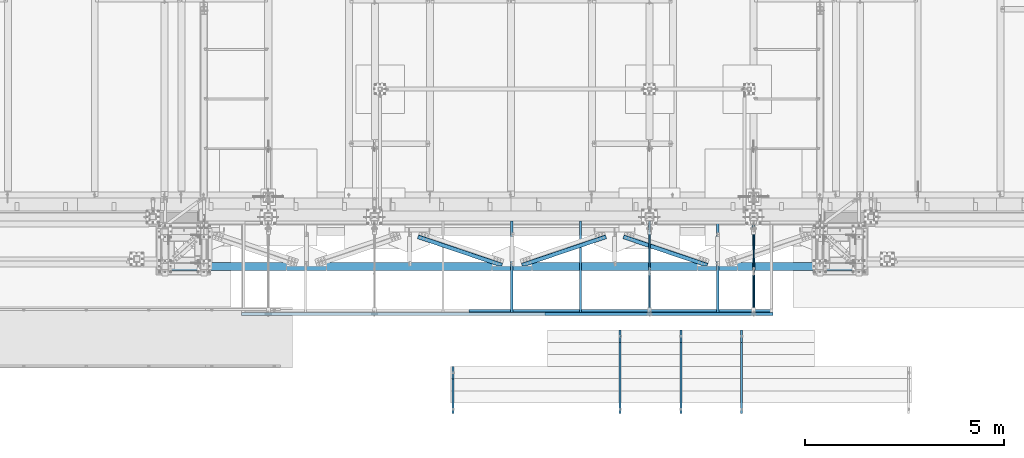
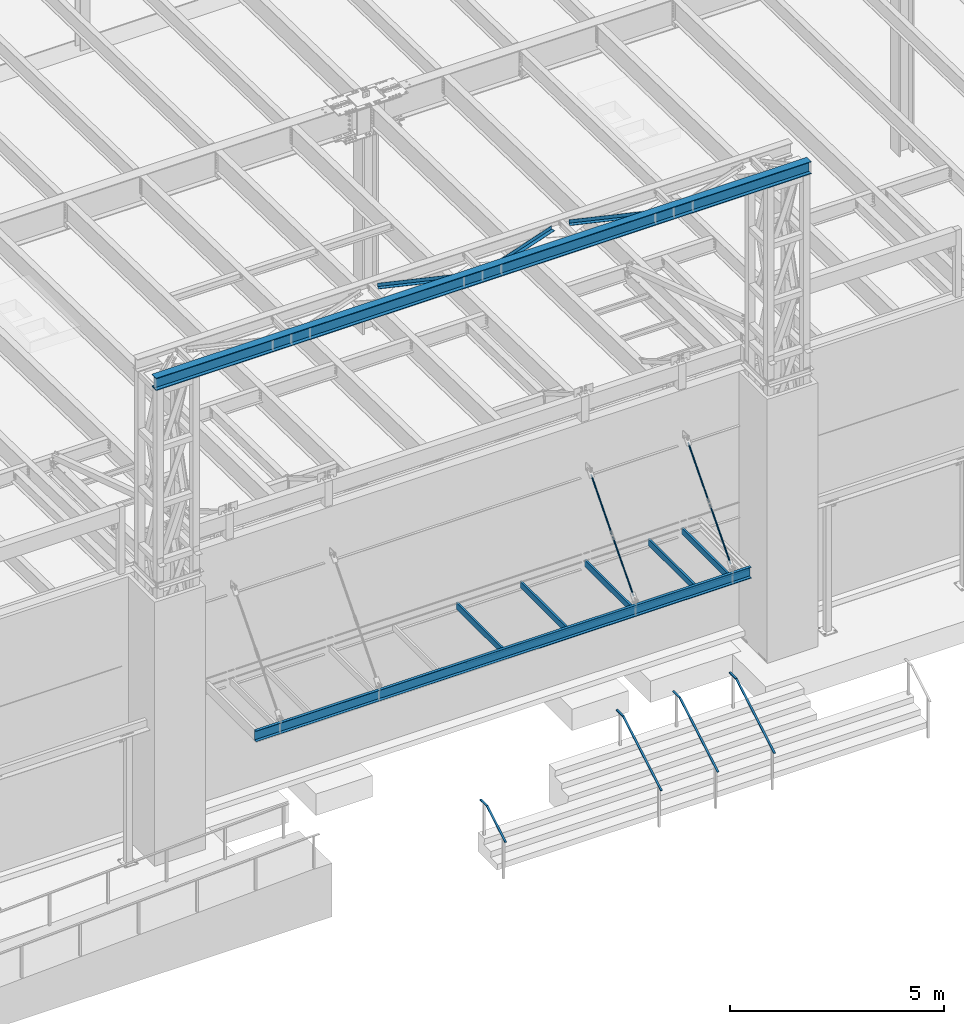
# One storey, part 1056 of 1763: 16 beams, 4 members, 16 elements without a shape of their own.
"""IFC2X3 building model written with IfcOpenShell, lengths in millimetres."""

from ifc_helpers import new_model, si_unit, frame, origin_with_axes, place, context, subcontext, project, spatial, faceted_brep, material, type_object, element, aggregate, save


model = new_model("IFC2X3")

# Units and contexts
model_context = context("Model", 3, precision=1e-05, world=origin_with_axes())
body_context = subcontext(model_context, "Body", "Model", "MODEL_VIEW")
ifc_project = project(units=[si_unit("LENGTHUNIT", "METRE", prefix="MILLI"), si_unit("AREAUNIT", "SQUARE_METRE"), si_unit("VOLUMEUNIT", "CUBIC_METRE"), si_unit("MASSUNIT", "GRAM", prefix="KILO"), si_unit("TIMEUNIT", "SECOND"), si_unit("PLANEANGLEUNIT", "RADIAN"), si_unit("SOLIDANGLEUNIT", "STERADIAN"), si_unit("THERMODYNAMICTEMPERATUREUNIT", "DEGREE_CELSIUS"), si_unit("LUMINOUSINTENSITYUNIT", "LUMEN")], contexts=[model_context])

# Site, building, storey
site_placement = place(None, origin_with_axes())
site = spatial("IfcSite", under=ifc_project, at=site_placement, CompositionType="ELEMENT")
building_placement = place(site_placement, origin_with_axes())
building = spatial("IfcBuilding", under=site, at=building_placement, Name="Undefined", CompositionType="ELEMENT")
storey_placement = place(building_placement, origin_with_axes())
storey = spatial("IfcBuildingStorey", under=building, at=storey_placement, Name="Undefined", CompositionType="ELEMENT", Elevation=0.0)

# Assembly, beam
assembly_1_placement = place(storey_placement, origin_with_axes())
assembly_1 = element("IfcElementAssembly", 1, at=assembly_1_placement, inside=storey, Name="BEAM", AssemblyPlace="NOTDEFINED", PredefinedType="RIGID_FRAME")
ifc_material_1 = material(Name="STEEL/A36")
beam_type_1 = type_object("IfcBeamType", Name="C12X20.7", PredefinedType="NOTDEFINED")
beam_1_placement = place(assembly_1_placement, frame((-62260.9785703209, -16643.3525869816, 8585.2), z_axis=(0.0, 0.0, 1.0), x_axis=(1.0, 0.0, 0.0)))
beam_1 = element("IfcBeam", 2, at=beam_1_placement, type_object=beam_type_1, material=ifc_material_1, Name="BEAM", ObjectType="C12X20.7", context=body_context, shape_type="Brep", body=[
    faceted_brep([(0.0, 38.1000000000004, -152.4), (0.0, 38.1000000000004, 152.4), (13347.3031240281, 38.0999999999985, 152.4), (13347.3031240281, 38.0999999999985, -152.4), (0.0, -38.1000000000004, 152.4), (13347.3031240281, -38.0999999999985, 152.4), (0.0, -38.1000000000004, 146.04746), (13347.3031240281, -38.0999999999985, 146.04746), (0.0, 30.1625000000004, 134.6749275), (13347.3031240281, 30.1624999999985, 134.6749275), (0.0, 30.1625000000004, -134.6749275), (13347.3031240281, 30.1624999999985, -134.6749275), (0.0, -38.1000000000004, -146.04746), (13347.3031240281, -38.0999999999985, -146.04746), (0.0, -38.1000000000004, -152.4), (13347.3031240281, -38.0999999999985, -152.4)], [[[0, 1, 2, 3]], [[1, 4, 5, 2]], [[4, 6, 7, 5]], [[6, 8, 9, 7]], [[8, 10, 11, 9]], [[10, 12, 13, 11]], [[12, 14, 15, 13]], [[14, 0, 3, 15]], [[5, 7, 9, 11, 13, 15, 3, 2]], [[14, 12, 10, 8, 6, 4, 1, 0]]]),
])

assembly_2_placement = place(storey_placement, origin_with_axes())
assembly_2 = element("IfcElementAssembly", 3, at=assembly_2_placement, inside=storey, Name="ANGLE", AssemblyPlace="NOTDEFINED", PredefinedType="RIGID_FRAME")
beam_type_2 = type_object("IfcBeamType", Name="L4X4X1/4", PredefinedType="NOTDEFINED")
beam_2_placement = place(assembly_2_placement, frame((-50331.0000497608, -15500.844871459, 18672.175), z_axis=(-0.320655198083929, -0.94719599024793, 0.0), x_axis=(-0.947195990247929, 0.320655198083932, 0.0)))
beam_2 = element("IfcBeam", 4, at=beam_2_placement, type_object=beam_type_2, material=ifc_material_1, Name="ANGLE", ObjectType="L4X4X1/4", context=body_context, shape_type="Brep", body=[
    faceted_brep([(248.939032899376, 44.4500000000007, 15.0208201336718), (248.939032899376, 50.7999999999993, 15.0208201336718), (248.93475632761, 50.7999999999993, -50.7999999996973), (248.93475632761, -50.7999999999993, -50.7999999996973), (248.935169854769, -50.7999999999993, -44.4499999997024), (248.935169854769, 44.4500000000007, -44.4499999997024), (354.581904417377, 44.4500000000007, 50.7769661094571), (354.58190441737, 50.7999999999993, 50.8000000003813), (2474.10695207783, 44.4500000000007, 50.7975799277119), (2474.10695220195, 50.7999999999993, 50.8000000027932), (2474.10174137646, 50.7999999999993, -50.7999999971726), (2474.10174137646, -50.7999999999993, -50.7999999971726), (2474.10206705305, -50.7999999999993, -44.449999997174), (2474.10206705305, 44.4500000000007, -44.449999997174)], [[[0, 1, 2, 3, 4, 5]], [[6, 7, 1, 0]], [[7, 6, 8, 9]], [[2, 1, 7, 9, 10]], [[3, 2, 10, 11]], [[4, 3, 11, 12]], [[5, 4, 12, 13]], [[6, 0, 5, 13, 8]], [[12, 11, 10, 9, 8, 13]]]),
])
aggregate(assembly_2, [beam_2])

assembly_3_placement = place(storey_placement, origin_with_axes())
assembly_3 = element("IfcElementAssembly", 5, at=assembly_3_placement, inside=storey, Name="ANGLE", AssemblyPlace="NOTDEFINED", PredefinedType="RIGID_FRAME")
beam_3_placement = place(assembly_3_placement, frame((-55489.3167822984, -15500.844871274, 18672.175), z_axis=(-0.320655198083929, -0.94719599024793, 0.0), x_axis=(-0.947195990247929, 0.320655198083932, 0.0)))
beam_3 = element("IfcBeam", 6, at=beam_3_placement, type_object=beam_type_2, material=ifc_material_1, Name="ANGLE", ObjectType="L4X4X1/4", context=body_context, shape_type="Brep", body=[
    faceted_brep([(248.939032899376, 44.4500000000007, 15.0208201336718), (248.939032899376, 50.7999999999993, 15.0208201336718), (248.93475632761, 50.7999999999993, -50.7999999996973), (248.93475632761, -50.7999999999993, -50.7999999996973), (248.935169854769, -50.7999999999993, -44.4499999997024), (248.935169854769, 44.4500000000007, -44.4499999997024), (354.581904417377, 44.4500000000007, 50.7769661094571), (354.58190441737, 50.7999999999993, 50.8000000003813), (2474.10695207783, 44.4500000000007, 50.7975799277119), (2474.10695220195, 50.7999999999993, 50.8000000027932), (2474.10174137646, 50.7999999999993, -50.7999999971726), (2474.10174137646, -50.7999999999993, -50.7999999971726), (2474.10206705305, -50.7999999999993, -44.449999997174), (2474.10206705305, 44.4500000000007, -44.449999997174)], [[[0, 1, 2, 3, 4, 5]], [[6, 7, 1, 0]], [[7, 6, 8, 9]], [[2, 1, 7, 9, 10]], [[3, 2, 10, 11]], [[4, 3, 11, 12]], [[5, 4, 12, 13]], [[6, 0, 5, 13, 8]], [[12, 11, 10, 9, 8, 13]]]),
])
aggregate(assembly_3, [beam_3])

assembly_4_placement = place(storey_placement, origin_with_axes())
assembly_4 = element("IfcElementAssembly", 7, at=assembly_4_placement, inside=storey, Name="ANGLE", AssemblyPlace="NOTDEFINED", PredefinedType="RIGID_FRAME")
beam_4_placement = place(assembly_4_placement, frame((-52877.5798425236, -14627.7198341673, 18672.175), z_axis=(0.320655215158338, -0.947195984467713, 0.0), x_axis=(-0.947195984467714, -0.320655215158336, 0.0)))
beam_4 = element("IfcBeam", 8, at=beam_4_placement, type_object=beam_type_2, material=ifc_material_1, Name="ANGLE", ObjectType="L4X4X1/4", context=body_context, shape_type="Brep", body=[
    faceted_brep([(2474.08815029644, 44.4500000000007, -44.4499999984348), (2474.08815029644, -50.7999999999993, -44.4499999984348), (2474.08778122983, -50.7999999999993, -50.7999999984352), (2474.08778122983, 50.7999999999993, -50.7999999984352), (2474.09159971638, 50.7999999999993, 15.0236743646817), (2474.09159971638, 44.4500000000007, 15.0236743646817), (2368.45312543344, 50.7999999999993, 50.8000000014833), (2368.45312543344, 44.4500000000007, 50.8000000014833), (248.928076724376, 44.4500000000007, 50.8000000001518), (248.921250277446, 44.4500000000007, -44.4499999998336), (248.921250277446, -50.7999999999993, -44.4499999998336), (248.920795180988, -50.7999999999993, -50.7999999998303), (248.920795180988, 50.7999999999993, -50.7999999998303), (248.928076724376, 50.7999999999993, 50.8000000001518)], [[[0, 1, 2, 3, 4, 5]], [[5, 4, 6, 7]], [[0, 5, 7, 8, 9]], [[1, 0, 9, 10]], [[2, 1, 10, 11]], [[3, 2, 11, 12]], [[6, 4, 3, 12, 13]], [[7, 6, 13, 8]], [[12, 11, 10, 9, 8, 13]]]),
])
aggregate(assembly_4, [beam_4])

# Beam
beam_type_3 = type_object("IfcBeamType", Name="L3X3X1/4", PredefinedType="NOTDEFINED")
beam_5_placement = place(assembly_1_placement, frame((-56554.3129440085, -16567.1521202467, 8648.7), z_axis=(0.0, 1.0, 0.0), x_axis=(1.0, 0.0, 0.0)))
beam_5 = element("IfcBeam", 9, at=beam_5_placement, type_object=beam_type_3, material=ifc_material_1, Name="ANGLE", ObjectType="L3X3X1/4", context=body_context, shape_type="Brep", body=[
    faceted_brep([(0.0, 38.0999999999985, -38.1000000000004), (0.0, 38.0999999999985, 38.1000000000004), (7620.00000001252, 38.1000000000004, 38.099999987593), (7620.00000001241, 38.1000000000004, -38.1000000124041), (0.0, 31.75, 38.1000000000058), (7620.00000001252, 31.75, 38.099999987593), (0.0, 31.75, -31.75), (7620.00000001241, 31.75, -31.7500000124055), (0.0, -38.1000000000004, -31.75), (7620.00000001241, -38.1000000000004, -31.7500000124055), (0.0, -38.0999999999985, -38.1000000000004), (7620.00000001241, -38.1000000000004, -38.1000000124041)], [[[0, 1, 2, 3]], [[1, 4, 5, 2]], [[4, 6, 7, 5]], [[6, 8, 9, 7]], [[8, 10, 11, 9]], [[10, 0, 3, 11]], [[5, 7, 9, 11, 3, 2]], [[10, 8, 6, 4, 1, 0]]]),
])

# Assembly, beam
assembly_5_placement = place(storey_placement, origin_with_axes())
assembly_5 = element("IfcElementAssembly", 10, at=assembly_5_placement, inside=storey, Name="HANDRAIL", AssemblyPlace="NOTDEFINED", PredefinedType="RIGID_FRAME")
beam_type_4 = type_object("IfcBeamType", PredefinedType="NOTDEFINED")
beam_6_placement = place(assembly_5_placement, frame((-52755.2372736984, -19143.8249145572, 5206.50837891029), z_axis=(-1.0, 0.0, 0.0), x_axis=(0.0, 0.863778900717086, 0.503871025834967)))
beam_6 = element("IfcBeam", 11, at=beam_6_placement, type_object=beam_type_4, material=ifc_material_1, Name="HANDRAIL", context=body_context, shape_type="Brep", body=[
    faceted_brep([(2.91038304567337e-11, -9.52499999999418, -25.4000000000015), (2.91038304567337e-11, -9.52499999999418, 25.4000000000015), (-5.82076609134674e-11, 9.52499999999418, 25.4000000000015), (-5.82076609134674e-11, 9.52499999999418, -25.4000000000015), (2065.19938791017, 9.52504462009711, 25.4000000000015), (2065.19938791017, 9.52504462009711, -25.4000000000015), (2070.3495392473, -9.52495526862185, -25.4000000000015), (2070.3495392473, -9.52495526862185, 25.4000000000015), (2326.25483773232, 161.807390474376, 25.4000000000015), (2326.25483773232, 161.807390474376, -25.4000000000015), (2335.85358077444, 145.352402415698, 25.4000000000015), (2335.85358077444, 145.352402415698, -25.4000000000015)], [[[0, 1, 2, 3]], [[3, 2, 4, 5]], [[1, 0, 6, 7]], [[5, 4, 8, 9]], [[4, 2, 1, 7, 10, 8]], [[7, 6, 11, 10]], [[6, 0, 3, 5, 9, 11]], [[10, 11, 9, 8]]]),
])
aggregate(assembly_5, [beam_6])

assembly_6_placement = place(storey_placement, origin_with_axes())
assembly_6 = element("IfcElementAssembly", 12, at=assembly_6_placement, inside=storey, Name="HANDRAIL", AssemblyPlace="NOTDEFINED", PredefinedType="RIGID_FRAME")
beam_7_placement = place(assembly_6_placement, frame((-49707.2372736984, -19143.8249145572, 5206.50837891029), z_axis=(-1.0, 0.0, 0.0), x_axis=(0.0, 0.863778900717086, 0.503871025834967)))
beam_7 = element("IfcBeam", 13, at=beam_7_placement, type_object=beam_type_4, material=ifc_material_1, Name="HANDRAIL", context=body_context, shape_type="Brep", body=[
    faceted_brep([(2.91038304567337e-11, -9.52499999999418, -25.4000000000015), (2.91038304567337e-11, -9.52499999999418, 25.4000000000015), (-5.82076609134674e-11, 9.52499999999418, 25.4000000000015), (-5.82076609134674e-11, 9.52499999999418, -25.4000000000015), (2065.19938791017, 9.52504462009711, 25.4000000000015), (2065.19938791017, 9.52504462009711, -25.4000000000015), (2070.3495392473, -9.52495526862185, -25.4000000000015), (2070.3495392473, -9.52495526862185, 25.4000000000015), (2326.25483773232, 161.807390474376, 25.4000000000015), (2326.25483773232, 161.807390474376, -25.4000000000015), (2335.85358077444, 145.352402415698, 25.4000000000015), (2335.85358077444, 145.352402415698, -25.4000000000015)], [[[0, 1, 2, 3]], [[3, 2, 4, 5]], [[1, 0, 6, 7]], [[5, 4, 8, 9]], [[4, 2, 1, 7, 10, 8]], [[7, 6, 11, 10]], [[6, 0, 3, 5, 9, 11]], [[10, 11, 9, 8]]]),
])
aggregate(assembly_6, [beam_7])

assembly_7_placement = place(storey_placement, origin_with_axes())
assembly_7 = element("IfcElementAssembly", 14, at=assembly_7_placement, inside=storey, Name="HANDRAIL", AssemblyPlace="NOTDEFINED", PredefinedType="RIGID_FRAME")
beam_8_placement = place(assembly_7_placement, frame((-51231.2372736984, -19143.8249145572, 5206.50837891029), z_axis=(-1.0, 0.0, 0.0), x_axis=(0.0, 0.863778900717086, 0.503871025834967)))
beam_8 = element("IfcBeam", 15, at=beam_8_placement, type_object=beam_type_4, material=ifc_material_1, Name="HANDRAIL", context=body_context, shape_type="Brep", body=[
    faceted_brep([(2.91038304567337e-11, -9.52499999999418, -25.4000000000015), (2.91038304567337e-11, -9.52499999999418, 25.4000000000015), (-5.82076609134674e-11, 9.52499999999418, 25.4000000000015), (-5.82076609134674e-11, 9.52499999999418, -25.4000000000015), (2065.19938791017, 9.52504462009711, 25.4000000000015), (2065.19938791017, 9.52504462009711, -25.4000000000015), (2070.3495392473, -9.52495526862185, -25.4000000000015), (2070.3495392473, -9.52495526862185, 25.4000000000015), (2326.25483773232, 161.807390474376, 25.4000000000015), (2326.25483773232, 161.807390474376, -25.4000000000015), (2335.85358077444, 145.352402415698, 25.4000000000015), (2335.85358077444, 145.352402415698, -25.4000000000015)], [[[0, 1, 2, 3]], [[3, 2, 4, 5]], [[1, 0, 6, 7]], [[5, 4, 8, 9]], [[4, 2, 1, 7, 10, 8]], [[7, 6, 11, 10]], [[6, 0, 3, 5, 9, 11]], [[10, 11, 9, 8]]]),
])
aggregate(assembly_7, [beam_8])

assembly_8_placement = place(storey_placement, origin_with_axes())
assembly_8 = element("IfcElementAssembly", 16, at=assembly_8_placement, inside=storey, Name="HANDRAIL", AssemblyPlace="NOTDEFINED", PredefinedType="RIGID_FRAME")
beam_9_placement = place(assembly_8_placement, frame((-56952.5872736984, -19143.8248832361, 5206.50837891029), z_axis=(-1.0, 0.0, 0.0), x_axis=(0.0, 0.863778900717086, 0.503871025834967)))
beam_9 = element("IfcBeam", 17, at=beam_9_placement, type_object=beam_type_4, material=ifc_material_1, Name="HANDRAIL", context=body_context, shape_type="Brep", body=[
    faceted_brep([(2.91038304567337e-11, -9.52499999999418, -25.4000000000015), (2.91038304567337e-11, -9.52499999999418, 25.4000000000015), (-5.82076609134674e-11, 9.52499999999418, 25.4000000000015), (-5.82076609134674e-11, 9.52499999999418, -25.4000000000015), (1006.59513807963, 9.52500455970767, 25.4000000000015), (1006.59513807963, 9.52500455970767, -25.4000000000015), (1011.74528904162, -9.52499541697944, -25.4000000000015), (1011.74528904162, -9.52499541697944, 25.4000000000015), (1267.65059126487, 161.807344696828, 25.4000000000015), (1267.65059126487, 161.807344696828, -25.4000000000015), (1277.2493339458, 145.352356427451, 25.4000000000015), (1277.2493339458, 145.352356427451, -25.4000000000015)], [[[0, 1, 2, 3]], [[3, 2, 4, 5]], [[1, 0, 6, 7]], [[5, 4, 8, 9]], [[4, 2, 1, 7, 10, 8]], [[7, 6, 11, 10]], [[6, 0, 3, 5, 9, 11]], [[10, 11, 9, 8]]]),
])
aggregate(assembly_8, [beam_9])

# Beam
beam_type_5 = type_object("IfcBeamType", PredefinedType="NOTDEFINED")
beam_10_placement = place(assembly_1_placement, frame((-54641.1770086929, -16605.2525498317, 8426.45000000022), z_axis=(0.0, 1.0, 0.0), x_axis=(1.0, 0.0, 0.0)))
beam_10 = element("IfcBeam", 18, at=beam_10_placement, type_object=beam_type_5, material=ifc_material_1, Name="PLATE", context=body_context, shape_type="Brep", body=[
    faceted_brep([(4.36557456851006e-11, 6.35000000000036, -76.2000000000044), (-4.72937244921923e-11, 6.35000000000036, 76.1999999999898), (5727.50156201937, 6.35000000000036, 76.2000000055705), (5727.50156201896, 6.35000000000036, -76.199999994431), (-4.72937244921923e-11, -6.35000000000036, 76.1999999999898), (5727.50156201937, -6.35000000000036, 76.2000000055705), (4.36557456851006e-11, -6.35000000000036, -76.2000000000044), (5727.50156201896, -6.35000000000036, -76.199999994431)], [[[0, 1, 2, 3]], [[1, 4, 5, 2]], [[4, 6, 7, 5]], [[6, 0, 3, 7]], [[5, 7, 3, 2]], [[6, 4, 1, 0]]]),
])

aggregate(assembly_1, [beam_5, beam_10, beam_1])

# Assembly, beam
assembly_9_placement = place(storey_placement, origin_with_axes())
assembly_9 = element("IfcElementAssembly", 19, at=assembly_9_placement, inside=storey, Name="BEAM", AssemblyPlace="NOTDEFINED", PredefinedType="RIGID_FRAME")
beam_type_6 = type_object("IfcBeamType", Name="C7X9.8", PredefinedType="NOTDEFINED")
beam_11_placement = place(assembly_9_placement, frame((-50306.508257937, -16605.2525869701, 8521.7), z_axis=(0.0, 0.0, 1.0), x_axis=(0.0, 1.0, 0.0)))
beam_11 = element("IfcBeam", 20, at=beam_11_placement, type_object=beam_type_6, material=ifc_material_1, Name="BEAM", ObjectType="C7X9.8", context=body_context, shape_type="Brep", body=[
    faceted_brep([(0.0, 26.9875000000029, -88.8999999999996), (0.0, 26.9875000000029, 88.8999999999996), (2295.52499752098, 26.9875000000029, 88.8999999999996), (2295.52499752098, 26.9875000000029, -88.8999999999996), (0.0, -26.9875000000029, 88.8999999999996), (2295.52499752098, -26.9875000000029, 88.8999999999996), (0.0, -26.9875000000029, 83.8711175000008), (2295.52499752098, -26.9875000000029, 83.8711175000008), (0.0, 22.2249999999985, 75.6723149999998), (2295.52499752098, 22.2249999999985, 75.6723149999998), (0.0, 22.2249999999985, -75.6723149999998), (2295.52499752098, 22.2249999999985, -75.6723149999998), (0.0, -26.9875000000029, -83.8711175000008), (2295.52499752098, -26.9875000000029, -83.8711175000008), (0.0, -26.9875000000029, -88.8999999999996), (2295.52499752098, -26.9875000000029, -88.8999999999996)], [[[0, 1, 2, 3]], [[1, 4, 5, 2]], [[4, 6, 7, 5]], [[6, 8, 9, 7]], [[8, 10, 11, 9]], [[10, 12, 13, 11]], [[12, 14, 15, 13]], [[14, 0, 3, 15]], [[5, 7, 9, 11, 13, 15, 3, 2]], [[14, 12, 10, 8, 6, 4, 1, 0]]]),
])
aggregate(assembly_9, [beam_11])

assembly_10_placement = place(storey_placement, origin_with_axes())
assembly_10 = element("IfcElementAssembly", 21, at=assembly_10_placement, inside=storey, Name="BEAM", AssemblyPlace="NOTDEFINED", PredefinedType="RIGID_FRAME")
beam_12_placement = place(assembly_10_placement, frame((-49402.4270083119, -16605.2526189353, 8521.7), z_axis=(0.0, 0.0, 1.0), x_axis=(0.0, 1.0, 0.0)))
beam_12 = element("IfcBeam", 22, at=beam_12_placement, type_object=beam_type_6, material=ifc_material_1, Name="BEAM", ObjectType="C7X9.8", context=body_context, shape_type="Brep", body=[
    faceted_brep([(0.0, 26.9875000000029, -88.8999999999996), (0.0, 26.9875000000029, 88.8999999999996), (2295.52499752098, 26.9875000000029, 88.8999999999996), (2295.52499752098, 26.9875000000029, -88.8999999999996), (0.0, -26.9875000000029, 88.8999999999996), (2295.52499752098, -26.9875000000029, 88.8999999999996), (0.0, -26.9875000000029, 83.8711175000008), (2295.52499752098, -26.9875000000029, 83.8711175000008), (0.0, 22.2249999999985, 75.6723149999998), (2295.52499752098, 22.2249999999985, 75.6723149999998), (0.0, 22.2249999999985, -75.6723149999998), (2295.52499752098, 22.2249999999985, -75.6723149999998), (0.0, -26.9875000000029, -83.8711175000008), (2295.52499752098, -26.9875000000029, -83.8711175000008), (0.0, -26.9875000000029, -88.8999999999996), (2295.52499752098, -26.9875000000029, -88.8999999999996)], [[[0, 1, 2, 3]], [[1, 4, 5, 2]], [[4, 6, 7, 5]], [[6, 8, 9, 7]], [[8, 10, 11, 9]], [[10, 12, 13, 11]], [[12, 14, 15, 13]], [[14, 0, 3, 15]], [[5, 7, 9, 11, 13, 15, 3, 2]], [[14, 12, 10, 8, 6, 4, 1, 0]]]),
])
aggregate(assembly_10, [beam_12])

assembly_11_placement = place(storey_placement, origin_with_axes())
assembly_11 = element("IfcElementAssembly", 23, at=assembly_11_placement, inside=storey, Name="BEAM", AssemblyPlace="NOTDEFINED", PredefinedType="RIGID_FRAME")
beam_13_placement = place(assembly_11_placement, frame((-52018.627008321, -16605.2521202467, 8521.7), z_axis=(0.0, 0.0, 1.0), x_axis=(0.0, 1.0, 0.0)))
beam_13 = element("IfcBeam", 24, at=beam_13_placement, type_object=beam_type_6, material=ifc_material_1, Name="BEAM", ObjectType="C7X9.8", context=body_context, shape_type="Brep", body=[
    faceted_brep([(0.0, 26.9875000000029, -88.8999999999996), (0.0, 26.9875000000029, 88.8999999999996), (2295.52453083604, 26.9875000000029, 88.8999999999996), (2295.52453083604, 26.9875000000029, -88.8999999999996), (0.0, -26.9875000000029, 88.8999999999996), (2295.52453083604, -26.9875000000029, 88.8999999999996), (0.0, -26.9875000000029, 83.8711175000008), (2295.52453083604, -26.9875000000029, 83.8711175000008), (0.0, 22.2249999999985, 75.6723149999998), (2295.52453083604, 22.2249999999985, 75.6723149999998), (0.0, 22.2249999999985, -75.6723149999998), (2295.52453083604, 22.2249999999985, -75.6723149999998), (0.0, -26.9875000000029, -83.8711175000008), (2295.52453083604, -26.9875000000029, -83.8711175000008), (0.0, -26.9875000000029, -88.8999999999996), (2295.52453083604, -26.9875000000029, -88.8999999999996)], [[[0, 1, 2, 3]], [[1, 4, 5, 2]], [[4, 6, 7, 5]], [[6, 8, 9, 7]], [[8, 10, 11, 9]], [[10, 12, 13, 11]], [[12, 14, 15, 13]], [[14, 0, 3, 15]], [[5, 7, 9, 11, 13, 15, 3, 2]], [[14, 12, 10, 8, 6, 4, 1, 0]]]),
])
aggregate(assembly_11, [beam_13])

assembly_12_placement = place(storey_placement, origin_with_axes())
assembly_12 = element("IfcElementAssembly", 25, at=assembly_12_placement, inside=storey, Name="BEAM", AssemblyPlace="NOTDEFINED", PredefinedType="RIGID_FRAME")
beam_14_placement = place(assembly_12_placement, frame((-53756.1457586958, -16605.2525869388, 8521.7), z_axis=(0.0, 0.0, 1.0), x_axis=(0.0, 1.0, 0.0)))
beam_14 = element("IfcBeam", 26, at=beam_14_placement, type_object=beam_type_6, material=ifc_material_1, Name="BEAM", ObjectType="C7X9.8", context=body_context, shape_type="Brep", body=[
    faceted_brep([(0.0, 26.9875000000029, -88.8999999999996), (0.0, 26.9875000000029, 88.8999999999996), (2295.52499752098, 26.9875000000029, 88.8999999999996), (2295.52499752098, 26.9875000000029, -88.8999999999996), (0.0, -26.9875000000029, 88.8999999999996), (2295.52499752098, -26.9875000000029, 88.8999999999996), (0.0, -26.9875000000029, 83.8711175000008), (2295.52499752098, -26.9875000000029, 83.8711175000008), (0.0, 22.2249999999985, 75.6723149999998), (2295.52499752098, 22.2249999999985, 75.6723149999998), (0.0, 22.2249999999985, -75.6723149999998), (2295.52499752098, 22.2249999999985, -75.6723149999998), (0.0, -26.9875000000029, -83.8711175000008), (2295.52499752098, -26.9875000000029, -83.8711175000008), (0.0, -26.9875000000029, -88.8999999999996), (2295.52499752098, -26.9875000000029, -88.8999999999996)], [[[0, 1, 2, 3]], [[1, 4, 5, 2]], [[4, 6, 7, 5]], [[6, 8, 9, 7]], [[8, 10, 11, 9]], [[10, 12, 13, 11]], [[12, 14, 15, 13]], [[14, 0, 3, 15]], [[5, 7, 9, 11, 13, 15, 3, 2]], [[14, 12, 10, 8, 6, 4, 1, 0]]]),
])
aggregate(assembly_12, [beam_14])

assembly_13_placement = place(storey_placement, origin_with_axes())
assembly_13 = element("IfcElementAssembly", 27, at=assembly_13_placement, inside=storey, Name="BEAM", AssemblyPlace="NOTDEFINED", PredefinedType="RIGID_FRAME")
beam_15_placement = place(assembly_13_placement, frame((-55480.9645090798, -16605.2525869325, 8521.7), z_axis=(0.0, 0.0, 1.0), x_axis=(0.0, 1.0, 0.0)))
beam_15 = element("IfcBeam", 28, at=beam_15_placement, type_object=beam_type_6, material=ifc_material_1, Name="BEAM", ObjectType="C7X9.8", context=body_context, shape_type="Brep", body=[
    faceted_brep([(0.0, 26.9875000000029, -88.8999999999996), (0.0, 26.9875000000029, 88.8999999999996), (2295.52499752098, 26.9875000000029, 88.8999999999996), (2295.52499752098, 26.9875000000029, -88.8999999999996), (0.0, -26.9875000000029, 88.8999999999996), (2295.52499752098, -26.9875000000029, 88.8999999999996), (0.0, -26.9875000000029, 83.8711175000008), (2295.52499752098, -26.9875000000029, 83.8711175000008), (0.0, 22.2249999999985, 75.6723149999998), (2295.52499752098, 22.2249999999985, 75.6723149999998), (0.0, 22.2249999999985, -75.6723149999998), (2295.52499752098, 22.2249999999985, -75.6723149999998), (0.0, -26.9875000000029, -83.8711175000008), (2295.52499752098, -26.9875000000029, -83.8711175000008), (0.0, -26.9875000000029, -88.8999999999996), (2295.52499752098, -26.9875000000029, -88.8999999999996)], [[[0, 1, 2, 3]], [[1, 4, 5, 2]], [[4, 6, 7, 5]], [[6, 8, 9, 7]], [[8, 10, 11, 9]], [[10, 12, 13, 11]], [[12, 14, 15, 13]], [[14, 0, 3, 15]], [[5, 7, 9, 11, 13, 15, 3, 2]], [[14, 12, 10, 8, 6, 4, 1, 0]]]),
])
aggregate(assembly_13, [beam_15])

# Assembly, members
assembly_14_placement = place(storey_placement, origin_with_axes())
assembly_14 = element("IfcElementAssembly", 29, at=assembly_14_placement, inside=storey, Name="HANGER ROD", AssemblyPlace="NOTDEFINED", PredefinedType="RIGID_FRAME")
ifc_material_2 = material()
member_type = type_object("IfcMemberType", PredefinedType="NOTDEFINED")
member_1_placement = place(assembly_14_placement, frame((-49402.4270098514, -15572.8018592845, 10059.9757394587), z_axis=(0.0, -0.751852283110682, 0.659331589097061), x_axis=(0.0, 0.659331589097062, 0.75185228311068)))
member_1 = element("IfcMember", 30, at=member_1_placement, type_object=member_type, material=ifc_material_2, Name="BEAM", context=body_context, shape_type="Brep", body=[
    faceted_brep([(1503.04093508851, -7.9375, -13.7481532849306), (1503.04093478259, 0.0, -15.8749999998545), (1503.04093508851, 7.9375, -13.7481532849306), (1503.04093592429, 13.7481532850798, -7.93749999985448), (1503.04093706599, 15.875, 1.41881173476577e-10), (1503.0409382077, 13.7481532850798, 7.93750000013824), (1503.04093904348, 7.9375, 13.748153285218), (1503.0409393494, 0.0, 15.8750000001382), (1503.04093904348, -7.9375, 13.748153285218), (1503.0409382077, -13.7481532850798, 7.93750000013824), (1503.04093706599, -15.875, 1.41881173476577e-10), (1503.04093592429, -13.7481532850798, -7.93749999985448), (25.399999995976, -7.93750000389264, 13.7481538153661), (25.3999999959769, -3.89263732358813e-09, 15.8750005302863), (25.3999999959751, -13.7481532889724, 7.93750053028998), (25.3999999959788, -15.8750000038926, 5.30293618794531e-07), (25.3999999959779, -13.7481532889724, -7.93749946969911), (25.3999999959797, -7.93750000389264, -13.7481527547752), (25.3999999959797, -3.89263732358813e-09, -15.8749994696918), (25.3999999959797, 7.93749999610736, -13.7481527547752), (25.3999999959779, 13.7481532811871, -7.93749946969911), (25.3999996185303, 15.8749999962647, 0.0), (25.3999999959751, 13.7481532811871, 7.93750053028998), (25.399999995976, 7.93749999610736, 13.7481538153661), (177.799999998953, 7.9375, 13.7481532850943)], [[[0, 1, 2, 3, 4, 5, 6, 7, 8, 9, 10, 11]], [[12, 8, 7, 13]], [[14, 9, 8, 12]], [[15, 10, 9, 14]], [[16, 11, 10, 15]], [[17, 0, 11, 16]], [[18, 1, 0, 17]], [[19, 2, 1, 18]], [[20, 3, 2, 19]], [[21, 4, 3, 20]], [[22, 5, 4, 21]], [[23, 24, 6, 5, 22]], [[23, 13, 7, 6, 24]], [[22, 21, 20, 19, 18, 17, 16, 15, 14, 12, 13, 23]]]),
])
member_2_placement = place(assembly_14_placement, frame((-49402.4270098475, -16643.3525869314, 8839.20000000015), z_axis=(0.0, -0.751852283110682, 0.659331589097061), x_axis=(0.0, 0.659331589097062, 0.75185228311068)))
member_2 = element("IfcMember", 31, at=member_2_placement, type_object=member_type, material=ifc_material_2, Name="HANGER ROD", context=body_context, shape_type="Brep", body=[
    faceted_brep([(120.649999999407, -13.7481532850798, 7.93750000002183), (120.649999999399, -7.9375, 13.7481532851089), (120.649999999397, 0.0, 15.8750000000327), (120.649999999399, 7.9375, 13.7481532851089), (120.649999999407, 13.7481532850798, 7.93750000002183), (120.649999999417, 15.875, 1.45519152283669e-11), (120.649999999425, 13.7481532850798, -7.93749999999272), (120.649999999432, 7.9375, -13.7481532850798), (120.649999999433, 0.0, -15.875), (120.649999999432, -7.9375, -13.7481532850798), (120.649999999425, -13.7481532850798, -7.93749999999272), (120.649999999417, -15.875, 1.45519152283669e-11), (1598.29093934174, 7.9375, 13.7481532763995), (1598.29093934174, 0.0, 15.8749999913271), (1598.29093934175, 13.7481532850798, 7.93749999131251), (1598.29093934176, 15.875, -8.70568328537047e-09), (1598.29093934177, 13.7481532850798, -7.93750000872024), (1598.29093934178, 7.9375, -13.7481532938109), (1598.29093934178, 0.0, -15.8750000087384), (1598.29093934178, -7.9375, -13.7481532938109), (1598.29093934177, -13.7481532850798, -7.93750000872024), (1598.29093934176, -15.875, -8.70568328537047e-09), (1598.29093934175, -13.7481532850798, 7.93749999131251), (1598.29093934174, -7.9375, 13.7481532763995)], [[[0, 1, 2, 3, 4, 5, 6, 7, 8, 9, 10, 11]], [[12, 3, 2, 13]], [[14, 4, 3, 12]], [[15, 5, 4, 14]], [[16, 6, 5, 15]], [[17, 7, 6, 16]], [[18, 8, 7, 17]], [[19, 9, 8, 18]], [[20, 10, 9, 19]], [[21, 11, 10, 20]], [[22, 0, 11, 21]], [[23, 1, 0, 22]], [[23, 13, 2, 1]], [[16, 15, 14, 12, 13, 23, 22, 21, 20, 19, 18, 17]]]),
])
aggregate(assembly_14, [member_1, member_2])

assembly_15_placement = place(storey_placement, origin_with_axes())
assembly_15 = element("IfcElementAssembly", 32, at=assembly_15_placement, inside=storey, Name="HANGER ROD", AssemblyPlace="NOTDEFINED", PredefinedType="RIGID_FRAME")
member_3_placement = place(assembly_15_placement, frame((-52018.627008321, -15572.8018593345, 10059.9757394587), z_axis=(0.0, -0.751852283110682, 0.659331589097061), x_axis=(0.0, 0.659331589097062, 0.75185228311068)))
member_3 = element("IfcMember", 33, at=member_3_placement, type_object=member_type, material=ifc_material_2, Name="BEAM", context=body_context, shape_type="Brep", body=[
    faceted_brep([(1503.04093508851, -7.9375, -13.7481532849306), (1503.04093478259, 0.0, -15.8749999998545), (1503.04093508851, 7.9375, -13.7481532849306), (1503.04093592429, 13.7481532850798, -7.93749999985448), (1503.04093706599, 15.875, 1.41881173476577e-10), (1503.0409382077, 13.7481532850798, 7.93750000013824), (1503.04093904348, 7.9375, 13.748153285218), (1503.0409393494, 0.0, 15.8750000001382), (1503.04093904348, -7.9375, 13.748153285218), (1503.0409382077, -13.7481532850798, 7.93750000013824), (1503.04093706599, -15.875, 1.41881173476577e-10), (1503.04093592429, -13.7481532850798, -7.93749999985448), (25.399999995976, -7.93750000389264, 13.7481538153661), (25.3999999959769, -3.89263732358813e-09, 15.8750005302863), (25.3999999959751, -13.7481532889724, 7.93750053028998), (25.3999999959788, -15.8750000038926, 5.30293618794531e-07), (25.3999999959779, -13.7481532889724, -7.93749946969911), (25.3999999959797, -7.93750000389264, -13.7481527547752), (25.3999999959797, -3.89263732358813e-09, -15.8749994696918), (25.3999999959797, 7.93749999610736, -13.7481527547752), (25.3999999959779, 13.7481532811871, -7.93749946969911), (25.3999996185303, 15.8749999962647, 0.0), (25.3999999959751, 13.7481532811871, 7.93750053028998), (25.399999995976, 7.93749999610736, 13.7481538153661), (177.799999998953, 7.9375, 13.7481532850943)], [[[0, 1, 2, 3, 4, 5, 6, 7, 8, 9, 10, 11]], [[12, 8, 7, 13]], [[14, 9, 8, 12]], [[15, 10, 9, 14]], [[16, 11, 10, 15]], [[17, 0, 11, 16]], [[18, 1, 0, 17]], [[19, 2, 1, 18]], [[20, 3, 2, 19]], [[21, 4, 3, 20]], [[22, 5, 4, 21]], [[23, 24, 6, 5, 22]], [[23, 13, 7, 6, 24]], [[22, 21, 20, 19, 18, 17, 16, 15, 14, 12, 13, 23]]]),
])
member_4_placement = place(assembly_15_placement, frame((-52018.627008321, -16643.3525869814, 8839.20000000015), z_axis=(0.0, -0.751852283110682, 0.659331589097061), x_axis=(0.0, 0.659331589097062, 0.75185228311068)))
member_4 = element("IfcMember", 34, at=member_4_placement, type_object=member_type, material=ifc_material_2, Name="HANGER ROD", context=body_context, shape_type="Brep", body=[
    faceted_brep([(120.649999999407, -13.7481532850798, 7.93750000002183), (120.649999999399, -7.9375, 13.7481532851089), (120.649999999397, 0.0, 15.8750000000327), (120.649999999399, 7.9375, 13.7481532851089), (120.649999999407, 13.7481532850798, 7.93750000002183), (120.649999999417, 15.875, 1.45519152283669e-11), (120.649999999425, 13.7481532850798, -7.93749999999272), (120.649999999432, 7.9375, -13.7481532850798), (120.649999999433, 0.0, -15.875), (120.649999999432, -7.9375, -13.7481532850798), (120.649999999425, -13.7481532850798, -7.93749999999272), (120.649999999417, -15.875, 1.45519152283669e-11), (1598.29093934174, 7.9375, 13.7481532763995), (1598.29093934174, 0.0, 15.8749999913271), (1598.29093934175, 13.7481532850798, 7.93749999131251), (1598.29093934176, 15.875, -8.70568328537047e-09), (1598.29093934177, 13.7481532850798, -7.93750000872024), (1598.29093934178, 7.9375, -13.7481532938109), (1598.29093934178, 0.0, -15.8750000087384), (1598.29093934178, -7.9375, -13.7481532938109), (1598.29093934177, -13.7481532850798, -7.93750000872024), (1598.29093934176, -15.875, -8.70568328537047e-09), (1598.29093934175, -13.7481532850798, 7.93749999131251), (1598.29093934174, -7.9375, 13.7481532763995)], [[[0, 1, 2, 3, 4, 5, 6, 7, 8, 9, 10, 11]], [[12, 3, 2, 13]], [[14, 4, 3, 12]], [[15, 5, 4, 14]], [[16, 6, 5, 15]], [[17, 7, 6, 16]], [[18, 8, 7, 17]], [[19, 9, 8, 18]], [[20, 10, 9, 19]], [[21, 11, 10, 20]], [[22, 0, 11, 21]], [[23, 1, 0, 22]], [[23, 13, 2, 1]], [[16, 15, 14, 12, 13, 23, 22, 21, 20, 19, 18, 17]]]),
])
aggregate(assembly_15, [member_3, member_4])

# Assembly, beam
assembly_16_placement = place(storey_placement, origin_with_axes())
assembly_16 = element("IfcElementAssembly", 35, at=assembly_16_placement, inside=storey, Name="BEAM", AssemblyPlace="NOTDEFINED", PredefinedType="RIGID_FRAME")
ifc_material_3 = material(Name="STEEL/A992")
beam_type_7 = type_object("IfcBeamType", Name="W14X53", PredefinedType="NOTDEFINED")
beam_16_placement = place(assembly_16_placement, frame((-64299.5277903703, -15452.7272094127, 18645.1875), z_axis=(0.0, 0.0, 1.0), x_axis=(1.0, 0.0, 0.0)))
beam_16 = element("IfcBeam", 36, at=beam_16_placement, type_object=beam_type_7, material=ifc_material_3, Name="BEAM", ObjectType="W14X53", context=body_context, shape_type="Brep", body=[
    faceted_brep([(2.69210431724787e-10, 101.599999999999, -176.212500000001), (2.69210431724787e-10, 101.599999999999, -158.75), (17653.0005866402, 101.599999985063, -158.75), (17653.0005866402, 101.599999985063, -176.212500000001), (1.45519152283669e-11, 4.76249999999891, -158.75), (17653.00058664, 4.76249998506319, -158.75), (1.45519152283669e-11, 4.76249999999891, 158.75), (17653.00058664, 4.76249998506319, 158.75), (2.69210431724787e-10, 101.599999999999, 158.75), (17653.0005866402, 101.599999985063, 158.75), (2.69210431724787e-10, 101.599999999999, 176.212500000001), (17653.0005866402, 101.599999985063, 176.212500000001), (-2.69210431724787e-10, -101.600000000002, 176.212500000001), (17653.0005866397, -101.600000014938, 176.212500000001), (-2.69210431724787e-10, -101.600000000002, 158.75), (17653.0005866397, -101.600000014938, 158.75), (-1.45519152283669e-11, -4.76250000000255, 158.75), (17653.0005866399, -4.76250001493827, 158.75), (-1.45519152283669e-11, -4.76250000000255, -158.75), (17653.0005866399, -4.76250001493827, -158.75), (-2.69210431724787e-10, -101.600000000002, -158.75), (17653.0005866397, -101.600000014938, -158.75), (-2.69210431724787e-10, -101.600000000002, -176.212500000001), (17653.0005866397, -101.600000014938, -176.212500000001)], [[[0, 1, 2, 3]], [[1, 4, 5, 2]], [[4, 6, 7, 5]], [[6, 8, 9, 7]], [[8, 10, 11, 9]], [[10, 12, 13, 11]], [[12, 14, 15, 13]], [[14, 16, 17, 15]], [[16, 18, 19, 17]], [[18, 20, 21, 19]], [[20, 22, 23, 21]], [[22, 0, 3, 23]], [[5, 7, 9, 11, 13, 15, 17, 19, 21, 23, 3, 2]], [[22, 20, 18, 16, 14, 12, 10, 8, 6, 4, 1, 0]]]),
])
aggregate(assembly_16, [beam_16])

save(model, "model.ifc")
